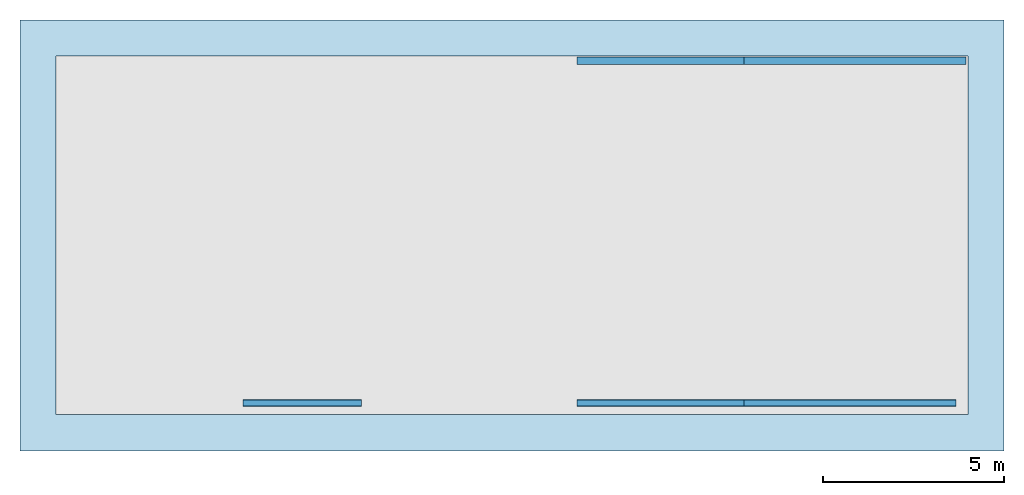
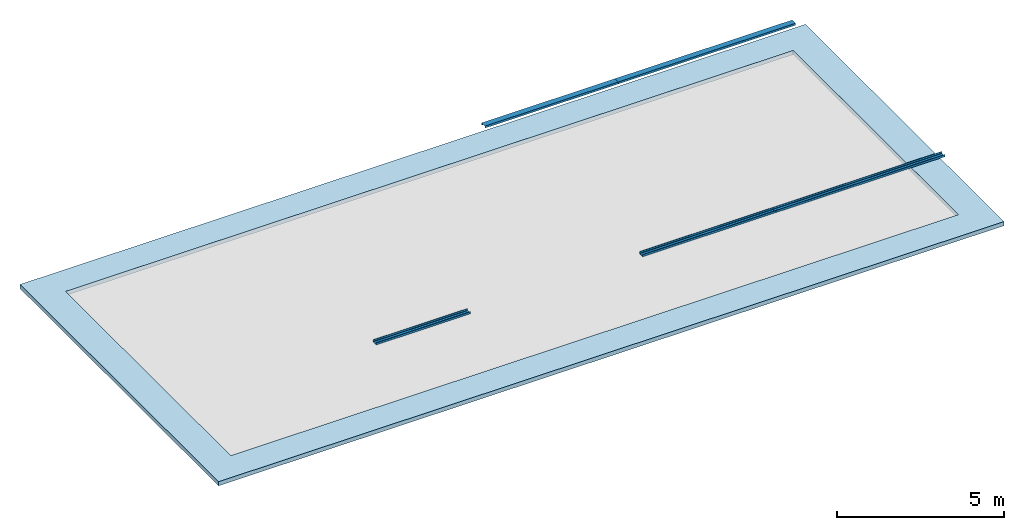
# One storey, part 1 of 2: 5 beams, 1 slab.
"""IFC2X3 building model written with IfcOpenShell, lengths in millimetres."""

import ifcopenshell
import ifcopenshell.guid

model = None  # the IFC model being written
_history = None  # IfcOwnerHistory: only IFC2X3 demands one
_inside = {}  # id of a spatial element -> (the spatial element, [elements in it])
_under = {}  # id of a project, library or spatial element -> (it, [spatial elements below it])
_declared = {}  # id of a project -> (the project, [libraries it declares])
_typed = {}  # id of a type object -> (the type object, [elements of that type])
_made_of = {}  # id of a material, layer set ... -> (it, [elements and type objects made of it])


def new_model(schema):
    """Start an empty IFC model of exactly this schema.

    Asked for "IFC4X3", IfcOpenShell would pick the latest addendum, in which some entities
    have other attributes; the version numbers below select the first issue.
    IFC2X3 requires an IfcOwnerHistory on every rooted entity: one is made here for all.
    """
    global model, _history
    if schema == "IFC4X3":
        model = ifcopenshell.file(schema_version=(4, 3, 0, 0))
    else:
        model = ifcopenshell.file(schema=schema)
    _inside.clear()
    _under.clear()
    _declared.clear()
    _typed.clear()
    _made_of.clear()
    _history = None
    if model.schema == "IFC2X3":
        org = make("IfcOrganization", Name="unknown")
        user = make(
            "IfcPersonAndOrganization",
            ThePerson=make("IfcPerson", FamilyName="unknown"),
            TheOrganization=org,
        )
        app = make(
            "IfcApplication",
            ApplicationDeveloper=org,
            Version="unknown",
            ApplicationFullName="unknown",
            ApplicationIdentifier="unknown",
        )
        _history = make(
            "IfcOwnerHistory",
            OwningUser=user,
            OwningApplication=app,
            ChangeAction="ADDED",
            CreationDate=0,
        )
    return model


def make(cls, **values):
    """One entity of the class cls with the attributes given. An attribute that is None is left unset."""
    return model.create_entity(
        cls, **{name: value for name, value in values.items() if value is not None}
    )


def entity(cls, *values):
    """Any entity or typed value of the class cls, its attributes in the order of the schema. None: left unset."""
    e = model.create_entity(cls)
    for i, value in enumerate(values):
        if value is not None:
            e[i] = value
    return e


def rooted(cls, **values):
    """An entity with a GlobalId (a new one), such as an element, a storey or a relation."""
    return make(cls, GlobalId=ifcopenshell.guid.new(), OwnerHistory=_history, **values)


def si_unit(unit_type, name, prefix=None):
    """IfcSIUnit, for example si_unit("LENGTHUNIT", "METRE", prefix="MILLI")."""
    return make("IfcSIUnit", UnitType=unit_type, Prefix=prefix, Name=name)


def converted_unit(unit_type, name, factor, base, dimensions=None, offset=None):
    """IfcConversionBasedUnit, such as the inch: factor (a typed value) times the base unit."""
    return make(
        "IfcConversionBasedUnit"
        if offset is None
        else "IfcConversionBasedUnitWithOffset",
        ConversionOffset=offset,
        Dimensions=None
        if dimensions is None
        else entity("IfcDimensionalExponents", *dimensions),
        UnitType=unit_type,
        Name=name,
        ConversionFactor=make(
            "IfcMeasureWithUnit", ValueComponent=factor, UnitComponent=base
        ),
    )


def money_unit(currency):
    """IfcMonetaryUnit."""
    return make("IfcMonetaryUnit", Currency=currency)


def assignment(units):
    """IfcUnitAssignment: the units of a project."""
    return None if units is None else make("IfcUnitAssignment", Units=units)


def point(xyz):
    """IfcCartesianPoint."""
    return None if xyz is None else make("IfcCartesianPoint", Coordinates=xyz)


def direction(xyz):
    """IfcDirection."""
    return None if xyz is None else make("IfcDirection", DirectionRatios=xyz)


def frame(location, z_axis=None, x_axis=None):
    """IfcAxis2Placement3D, a coordinate frame: its origin and axes. An axis left out is left unset."""
    return make(
        "IfcAxis2Placement3D",
        Location=point(location),
        Axis=direction(z_axis),
        RefDirection=direction(x_axis),
    )


def frame_2d(location, x_axis=None):
    """IfcAxis2Placement2D, a coordinate frame in the plane: its origin and x axis."""
    return make(
        "IfcAxis2Placement2D", Location=point(location), RefDirection=direction(x_axis)
    )


def origin_with_axes():
    """The frame at (0, 0, 0) with the z axis (0, 0, 1) and the x axis (1, 0, 0) written out."""
    return frame((0.0, 0.0, 0.0), z_axis=(0.0, 0.0, 1.0), x_axis=(1.0, 0.0, 0.0))


def place(relative_to, where):
    """IfcLocalPlacement: puts the frame where relative to a parent placement (None: the world)."""
    return make(
        "IfcLocalPlacement", PlacementRelTo=relative_to, RelativePlacement=where
    )


def context(
    kind, dimensions, precision=None, world=None, true_north=None, identifier=None
):
    """IfcGeometricRepresentationContext, for example the 3D "Model" context."""
    return make(
        "IfcGeometricRepresentationContext",
        ContextIdentifier=identifier,
        ContextType=kind,
        CoordinateSpaceDimension=dimensions,
        Precision=precision,
        WorldCoordinateSystem=world,
        TrueNorth=true_north,
    )


def subcontext(parent, identifier, kind, view, scale=None):
    """IfcGeometricRepresentationSubContext, for example "Body" below "Model"."""
    return make(
        "IfcGeometricRepresentationSubContext",
        ContextIdentifier=identifier,
        ContextType=kind,
        ParentContext=parent,
        TargetScale=scale,
        TargetView=view,
    )


def project(units=None, contexts=None):
    """IfcProject with its units and contexts."""
    return rooted(
        "IfcProject",
        Name="project",
        RepresentationContexts=contexts,
        UnitsInContext=assignment(units),
    )


def spatial(cls, under=None, at=None, **own):
    """A site, building, storey or space (cls), placed at a placement, below another one or the project."""
    s = rooted(cls, ObjectPlacement=at, **own)
    if under is not None:
        _under.setdefault(under.id(), (under, []))[1].append(s)
    return s


def polyline(points):
    """IfcPolyline through the points."""
    return make("IfcPolyline", Points=[point(p) for p in points])


def circle_curve(where, radius):
    """IfcCircle in the frame where."""
    return make("IfcCircle", Position=where, Radius=radius)


def parameter(value):
    """IfcParameterValue: where a trimmed curve begins or ends, as a parameter of its basis curve."""
    return model.create_entity("IfcParameterValue", value)


def trimmed(basis, trim1, trim2, sense, master):
    """IfcTrimmedCurve: the piece of a basis curve between two trims."""
    return make(
        "IfcTrimmedCurve",
        BasisCurve=basis,
        Trim1=trim1,
        Trim2=trim2,
        SenseAgreement=sense,
        MasterRepresentation=master,
    )


def segment(curve, same_sense, transition):
    """IfcCompositeCurveSegment."""
    return make(
        "IfcCompositeCurveSegment",
        Transition=transition,
        SameSense=same_sense,
        ParentCurve=curve,
    )


def composite_curve(segments, self_intersect=None):
    """IfcCompositeCurve: segments joined end to end."""
    return make("IfcCompositeCurve", Segments=segments, SelfIntersect=self_intersect)


def outline(outer, holes=None, kind="AREA"):
    """IfcArbitraryClosedProfileDef: a profile drawn as a closed curve; with holes, ...WithVoids."""
    if holes is None:
        return make("IfcArbitraryClosedProfileDef", ProfileType=kind, OuterCurve=outer)
    return make(
        "IfcArbitraryProfileDefWithVoids",
        ProfileType=kind,
        OuterCurve=outer,
        InnerCurves=holes,
    )


def extrude(swept, where, along, depth):
    """IfcExtrudedAreaSolid: the profile swept, set in the frame where, extruded along a direction by depth."""
    return make(
        "IfcExtrudedAreaSolid",
        SweptArea=swept,
        Position=where,
        ExtrudedDirection=direction(along),
        Depth=depth,
    )


def boolean(op, a, b):
    """IfcBooleanResult of two solids."""
    return make("IfcBooleanResult", Operator=op, FirstOperand=a, SecondOperand=b)


def faces_of(points, faces, orient=None, outer=None):
    """IfcFace entities. A face is a list of loops; a loop is a list of indices into points, from 0.

    orient and outer hold one flag for each loop. By default every Orientation is true, the
    first loop of a face is its IfcFaceOuterBound and the others are IfcFaceBound.
    """
    made = []
    for i, loops in enumerate(faces):
        bounds = []
        for j, loop in enumerate(loops):
            is_outer = j == 0 if outer is None else outer[i][j]
            bounds.append(
                make(
                    "IfcFaceOuterBound" if is_outer else "IfcFaceBound",
                    Bound=make("IfcPolyLoop", Polygon=[points[k] for k in loop]),
                    Orientation=True if orient is None else orient[i][j],
                )
            )
        made.append(make("IfcFace", Bounds=bounds))
    return made


def faceted_brep(points, faces, orient=None, outer=None, voids=None):
    """IfcFacetedBrep: a solid bounded by flat faces; with voids (closed shells), ...WithVoids."""
    shared = [point(p) for p in points]
    hull = make("IfcClosedShell", CfsFaces=faces_of(shared, faces, orient, outer))
    if voids is None:
        return make("IfcFacetedBrep", Outer=hull)
    return make(
        "IfcFacetedBrepWithVoids",
        Outer=hull,
        Voids=[
            make(cls, CfsFaces=faces_of(shared, fs, o, b)) for cls, fs, o, b in voids
        ],
    )


def shape(context_of_items, identifier, shape_type, items):
    """IfcShapeRepresentation: the items that make up one representation, for example the "Body"."""
    return make(
        "IfcShapeRepresentation",
        ContextOfItems=context_of_items,
        RepresentationIdentifier=identifier,
        RepresentationType=shape_type,
        Items=items,
    )


def material(Name=None, Category=None):
    """IfcMaterial."""
    return make("IfcMaterial", Name=Name, Category=Category)


def layer(
    of_material, thickness, ventilated=None, Name=None, Category=None, Priority=None
):
    """IfcMaterialLayer: one layer of a wall or slab, of a material (None: an air gap)."""
    return make(
        "IfcMaterialLayer",
        Material=of_material,
        LayerThickness=thickness,
        IsVentilated=ventilated,
        Name=Name,
        Category=Category,
        Priority=Priority,
    )


def layer_set(layers, Name=None):
    """IfcMaterialLayerSet."""
    return make("IfcMaterialLayerSet", MaterialLayers=layers, LayerSetName=Name)


def layer_usage(for_layer_set, set_direction, sense, offset, extent=None):
    """IfcMaterialLayerSetUsage: how a layer set lies in its element."""
    return make(
        "IfcMaterialLayerSetUsage",
        ForLayerSet=for_layer_set,
        LayerSetDirection=set_direction,
        DirectionSense=sense,
        OffsetFromReferenceLine=offset,
        ReferenceExtent=extent,
    )


def made_of(thing, what):
    """Note that an element or type object is made of a material, layer set ...; save() writes the relation."""
    if what is not None:
        _made_of.setdefault(what.id(), (what, []))[1].append(thing)
    return thing


def type_object(cls, material=None, **own):
    """A type object (cls), such as IfcWallType, which elements share."""
    return made_of(rooted(cls, **own), material)


def element(
    cls,
    number,
    at=None,
    inside=None,
    cuts=None,
    type_object=None,
    material=None,
    context=None,
    identifier="Body",
    shape_type=None,
    held_by="IfcProductDefinitionShape",
    body=None,
    shapes=None,
    **own,
):
    """One element of the class cls, such as IfcWall. Its Tag is "e" and its number.

    at: its placement. inside: the storey or other place that contains it. cuts: it is an
    opening in that element (IfcRelVoidsElement). A single representation is given by context,
    identifier, shape_type and body (its items); several are given by shapes. held_by: the class
    of the entity that holds the representations. save() writes the other relations.
    """
    e = rooted(cls, Tag="e%d" % number, ObjectPlacement=at, **own)
    if body is not None:
        shapes = [shape(context, identifier, shape_type, body)]
    if shapes is not None:
        e.Representation = make(held_by, Representations=shapes)
    if inside is not None:
        _inside.setdefault(inside.id(), (inside, []))[1].append(e)
    if cuts is not None:
        rooted(
            "IfcRelVoidsElement", RelatingBuildingElement=cuts, RelatedOpeningElement=e
        )
    if type_object is not None:
        _typed.setdefault(type_object.id(), (type_object, []))[1].append(e)
    return made_of(e, material)


def aggregate(whole, parts):
    """IfcRelAggregates: a whole, such as a stair, and the parts it consists of."""
    return rooted("IfcRelAggregates", RelatingObject=whole, RelatedObjects=parts)


def save(model, path):
    """Write the relations noted so far, then the file.

    IfcRelAggregates (storeys below a building ...), IfcRelContainedInSpatialStructure (elements
    in a storey), IfcRelDefinesByType, IfcRelAssociatesMaterial and IfcRelDeclares: one each for
    every whole, place, type object, material and project.
    """
    for whole, parts in _under.values():
        aggregate(whole, parts)
    for where, things in _inside.values():
        rooted(
            "IfcRelContainedInSpatialStructure",
            RelatedElements=things,
            RelatingStructure=where,
        )
    for kind, things in _typed.values():
        rooted("IfcRelDefinesByType", RelatedObjects=things, RelatingType=kind)
    for what, things in _made_of.values():
        rooted("IfcRelAssociatesMaterial", RelatedObjects=things, RelatingMaterial=what)
    for by, libraries in _declared.values():
        rooted("IfcRelDeclares", RelatingContext=by, RelatedDefinitions=libraries)
    model.write(path)


model = new_model("IFC2X3")

# Units and contexts
model_context = context("Model", 3, precision=1e-05, world=origin_with_axes(), true_north=direction((0.0, 1.0)))
body_context = subcontext(model_context, "Body", "Model", "MODEL_VIEW")
ifc_project = project(units=[si_unit("LENGTHUNIT", "METRE", prefix="MILLI"), si_unit("AREAUNIT", "SQUARE_METRE"), si_unit("VOLUMEUNIT", "CUBIC_METRE"), converted_unit("PLANEANGLEUNIT", "DEGREE", entity("IfcPlaneAngleMeasure", 0.0174532925199), si_unit("PLANEANGLEUNIT", "RADIAN"), dimensions=[0, 0, 0, 0, 0, 0, 0]), si_unit("SOLIDANGLEUNIT", "STERADIAN"), money_unit("USD"), converted_unit("TIMEUNIT", "Year", entity("IfcTimeMeasure", 31556926.0), si_unit("TIMEUNIT", "SECOND"), dimensions=[0, 0, 0, 0, 0, 0, 0]), si_unit("MASSUNIT", "GRAM"), si_unit("THERMODYNAMICTEMPERATUREUNIT", "DEGREE_CELSIUS"), si_unit("LUMINOUSINTENSITYUNIT", "LUMEN")], contexts=[model_context])

# Site, building, storey
site_placement = place(None, origin_with_axes())
site = spatial("IfcSite", under=ifc_project, at=site_placement, CompositionType="ELEMENT")
building_placement = place(site_placement, origin_with_axes())
building = spatial("IfcBuilding", under=site, at=building_placement, CompositionType="ELEMENT")
storey_placement = place(building_placement, frame((0.0, 0.0, 70550.0), z_axis=(0.0, 0.0, 1.0), x_axis=(1.0, 0.0, 0.0)))
storey = spatial("IfcBuildingStorey", under=building, at=storey_placement, Name="0 Ground Level", CompositionType="ELEMENT", Elevation=70550.0)

# Beams
ifc_material_1 = material(Name="Metal - Steel 43-275")
beam_type_1 = type_object("IfcBeamType", Name="PFC200x75x23 (1) 75 x 200", PredefinedType="NOTDEFINED")
beam_1_placement = place(storey_placement, frame((10556.4431324, -1047.53631946, 2284.8), z_axis=(0.0, 0.0, 1.0), x_axis=(0.0, 1.0, 0.0)))
element("IfcBeam", 1, at=beam_1_placement, inside=storey, type_object=beam_type_1, material=ifc_material_1, Name="PFC-Parallel Flange Channels:PFC200x75x23", ObjectType="PFC-Parallel Flange Channels:PFC200x75x23", context=body_context, shape_type="SweptSolid", body=[
    extrude(outline(composite_curve([segment(polyline([(-40.2, -100.0), (34.8, -100.0), (34.8, 100.0), (-40.2, 100.0), (-40.2, 87.5), (16.8, 87.5)]), True, "CONTINUOUS"), segment(trimmed(circle_curve(frame_2d((16.8, 75.5), x_axis=(1.0, 0.0)), 12.0), [point((16.8, 87.5)), parameter(90.0)], [point((28.8, 75.5)), parameter(0.0)], False, "CARTESIAN"), True, "CONTINUOUS"), segment(polyline([(28.8, 75.5), (28.8, -75.5)]), True, "CONTINUOUS"), segment(trimmed(circle_curve(frame_2d((16.8, -75.5), x_axis=(0.0, -1.0)), 12.0), [point((28.8, -75.5)), parameter(90.0)], [point((16.8, -87.5)), parameter(0.0)], False, "CARTESIAN"), True, "CONTINUOUS"), segment(polyline([(16.8, -87.5), (-40.2, -87.5), (-40.2, -100.0)]), True, "CONTINUOUS")], self_intersect=False)), frame((0.0, 4610.2, 0.0), z_axis=(0.0, -1.0, 0.0), x_axis=(0.0, 0.0, -1.0)), (0.0, 0.0, 1.0), 4610.2),
])
beam_2_placement = place(storey_placement, frame((16408.3791118, -1047.53631946, 2284.8), z_axis=(0.0, 0.0, 1.0), x_axis=(0.0, 1.0, 0.0)))
element("IfcBeam", 2, at=beam_2_placement, inside=storey, type_object=beam_type_1, material=ifc_material_1, Name="PFC-Parallel Flange Channels:PFC200x75x23", ObjectType="PFC-Parallel Flange Channels:PFC200x75x23", context=body_context, shape_type="SweptSolid", body=[
    extrude(outline(composite_curve([segment(polyline([(-40.2, -100.0), (34.8, -100.0), (34.8, 100.0), (-40.2, 100.0), (-40.2, 87.5), (16.8, 87.5)]), True, "CONTINUOUS"), segment(trimmed(circle_curve(frame_2d((16.8, 75.5), x_axis=(1.0, 0.0)), 12.0), [point((16.8, 87.5)), parameter(90.0)], [point((28.8, 75.5)), parameter(0.0)], False, "CARTESIAN"), True, "CONTINUOUS"), segment(polyline([(28.8, 75.5), (28.8, -75.5)]), True, "CONTINUOUS"), segment(trimmed(circle_curve(frame_2d((16.8, -75.5), x_axis=(0.0, -1.0)), 12.0), [point((28.8, -75.5)), parameter(90.0)], [point((16.8, -87.5)), parameter(0.0)], False, "CARTESIAN"), True, "CONTINUOUS"), segment(polyline([(16.8, -87.5), (-40.2, -87.5), (-40.2, -100.0)]), True, "CONTINUOUS")], self_intersect=False)), frame((0.0, 5852.0, 0.0), z_axis=(0.0, -1.0, 0.0), x_axis=(0.0, 0.0, -1.0)), (0.0, 0.0, 1.0), 5852.0),
])
beam_3_placement = place(storey_placement, frame((-6.62088657266, -1047.53631946, 2284.8), z_axis=(0.0, 0.0, 1.0), x_axis=(0.0, 1.0, 0.0)))
element("IfcBeam", 3, at=beam_3_placement, inside=storey, type_object=beam_type_1, material=ifc_material_1, Name="PFC-Parallel Flange Channels:PFC200x75x23", ObjectType="PFC-Parallel Flange Channels:PFC200x75x23", context=body_context, shape_type="SweptSolid", body=[
    extrude(outline(composite_curve([segment(polyline([(-40.2, -100.0), (34.8, -100.0), (34.8, 100.0), (-40.2, 100.0), (-40.2, 87.5), (16.8, 87.5)]), True, "CONTINUOUS"), segment(trimmed(circle_curve(frame_2d((16.8, 75.5), x_axis=(1.0, 0.0)), 12.0), [point((16.8, 87.5)), parameter(90.0)], [point((28.8, 75.5)), parameter(0.0)], False, "CARTESIAN"), True, "CONTINUOUS"), segment(polyline([(28.8, 75.5), (28.8, -75.5)]), True, "CONTINUOUS"), segment(trimmed(circle_curve(frame_2d((16.8, -75.5), x_axis=(0.0, -1.0)), 12.0), [point((28.8, -75.5)), parameter(90.0)], [point((16.8, -87.5)), parameter(0.0)], False, "CARTESIAN"), True, "CONTINUOUS"), segment(polyline([(16.8, -87.5), (-40.2, -87.5), (-40.2, -100.0)]), True, "CONTINUOUS")], self_intersect=False)), frame((0.0, 3267.6, 0.0), z_axis=(0.0, -1.0, 0.0), x_axis=(0.0, 0.0, -1.0)), (0.0, 0.0, 1.0), 3267.6),
])
beam_type_2 = type_object("IfcBeamType", Name="PFC200x75x23 (2) 75 x 200", PredefinedType="NOTDEFINED")
beam_4_placement = place(storey_placement, frame((16683.7791134, 8402.49616284, 1265.2), z_axis=(0.0, 0.0, 1.0), x_axis=(0.0, 1.0, 0.0)))
element("IfcBeam", 4, at=beam_4_placement, inside=storey, type_object=beam_type_2, material=ifc_material_1, Name="PFC-Parallel Flange Channels:PFC200x75x23", ObjectType="PFC-Parallel Flange Channels:PFC200x75x23", context=body_context, shape_type="SweptSolid", body=[
    extrude(outline(composite_curve([segment(polyline([(-34.7999999999, -100.0), (40.2000000001, -100.0), (40.2000000001, -87.5), (-16.7999999999, -87.5)]), True, "CONTINUOUS"), segment(trimmed(circle_curve(frame_2d((-16.7999999999, -75.4999999999), x_axis=(-1.0, 0.0)), 12.0000000001), [point((-16.7999999999, -87.5)), parameter(90.0)], [point((-28.8, -75.5)), parameter(0.0)], False, "CARTESIAN"), True, "CONTINUOUS"), segment(polyline([(-28.8, -75.5), (-28.8, 75.5)]), True, "CONTINUOUS"), segment(trimmed(circle_curve(frame_2d((-16.8, 75.5), x_axis=(0.0, 1.0)), 12.0), [point((-28.8, 75.5)), parameter(90.0)], [point((-16.8, 87.5)), parameter(0.0)], False, "CARTESIAN"), True, "CONTINUOUS"), segment(polyline([(-16.8, 87.5), (40.2, 87.5), (40.2, 100.0), (-34.8, 100.0), (-34.7999999999, -100.0)]), True, "CONTINUOUS")], self_intersect=False)), frame((0.0, 6127.37498725, 0.0), z_axis=(0.0, -1.0, 0.0), x_axis=(0.0, 0.0, -1.0)), (0.0, 0.0, 1.0), 6127.37498725),
])
beam_5_placement = place(storey_placement, frame((10556.4041262, 8402.49616284, 1265.2), z_axis=(0.0, 0.0, 1.0), x_axis=(0.0, 1.0, 0.0)))
element("IfcBeam", 5, at=beam_5_placement, inside=storey, type_object=beam_type_2, material=ifc_material_1, Name="PFC-Parallel Flange Channels:PFC200x75x23", ObjectType="PFC-Parallel Flange Channels:PFC200x75x23", context=body_context, shape_type="SweptSolid", body=[
    extrude(outline(composite_curve([segment(polyline([(-34.7999999999, -100.0), (40.2000000001, -100.0), (40.2000000001, -87.5), (-16.7999999999, -87.5)]), True, "CONTINUOUS"), segment(trimmed(circle_curve(frame_2d((-16.7999999999, -75.4999999999), x_axis=(-1.0, 0.0)), 12.0000000001), [point((-16.7999999999, -87.5)), parameter(90.0)], [point((-28.8, -75.5)), parameter(0.0)], False, "CARTESIAN"), True, "CONTINUOUS"), segment(polyline([(-28.8, -75.5), (-28.8, 75.5)]), True, "CONTINUOUS"), segment(trimmed(circle_curve(frame_2d((-16.8, 75.5), x_axis=(0.0, 1.0)), 12.0), [point((-28.8, 75.5)), parameter(90.0)], [point((-16.8, 87.5)), parameter(0.0)], False, "CARTESIAN"), True, "CONTINUOUS"), segment(polyline([(-16.8, 87.5), (40.2, 87.5), (40.2, 100.0), (-34.8, 100.0), (-34.7999999999, -100.0)]), True, "CONTINUOUS")], self_intersect=False)), frame((0.0, 4610.20833758, 0.0), z_axis=(0.0, -1.0, 0.0), x_axis=(0.0, 0.0, -1.0)), (0.0, 0.0, 1.0), 4610.20833758),
])

# Slab
ifc_material_2 = material(Name="Concrete, Cast In Situ")
ifc_layer = layer(ifc_material_2, 150.0, ventilated="UNKNOWN")
ifc_layer_set = layer_set([ifc_layer], Name="Concrete, Cast In Situ 150")
ifc_layer_usage = layer_usage(ifc_layer_set, "AXIS3", "NEGATIVE", 150.0)
slab_type = type_object("IfcSlabType", Name="Concrete, Cast In Situ 150", PredefinedType="FLOOR")
slab_placement = place(storey_placement, frame((17738.0295383, 9527.27990658, 0.0), z_axis=(0.0, 0.0, 1.0), x_axis=(1.0, 0.0, 0.0)))
element("IfcSlab", 6, at=slab_placement, inside=storey, type_object=slab_type, material=ifc_layer_usage, PredefinedType="FLOOR", context=body_context, shape_type="CSG", body=[
    boolean("DIFFERENCE", extrude(outline(polyline([(0.0, 0.0), (-27174.2504249, 0.0), (-27174.2504249, -11899.5999698), (0.0, -11899.5999698), (0.0, 0.0)])), origin_with_axes(), (0.0, 0.0, 1.0), 150.0), faceted_brep([(-26174.2504249, -10899.5999698, 0.0), (-26174.2504249, -1000.0, 0.0), (-1000.0, -1000.0, 0.0), (-1000.0, -10899.5999698, 0.0), (-26174.2504249, -10899.5999698, 150.0), (-26174.2504249, -1000.0, 150.0), (-1000.0, -1000.0, 150.0), (-1000.0, -10899.5999698, 150.0)], [[[0, 1, 2, 3]], [[4, 5, 1, 0]], [[5, 6, 2, 1]], [[6, 7, 3, 2]], [[7, 4, 0, 3]], [[4, 7, 6, 5]]])),
])

save(model, "model.ifc")
